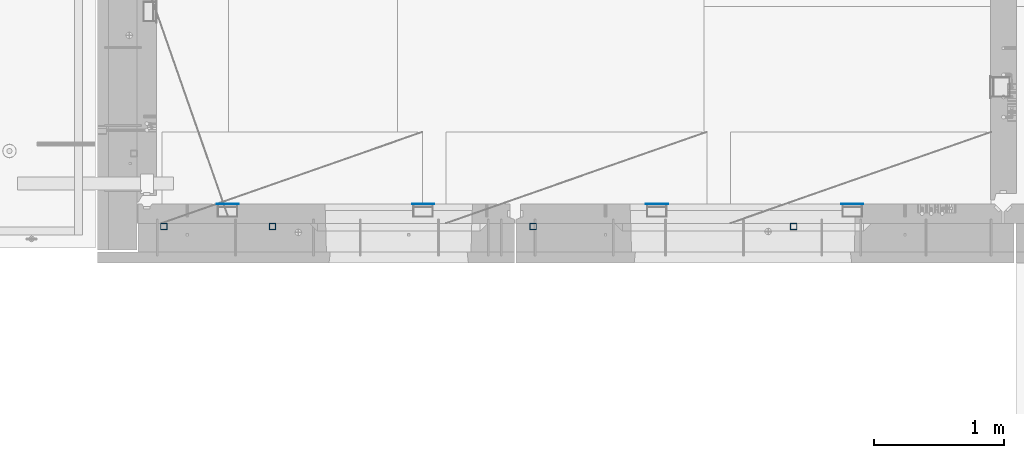
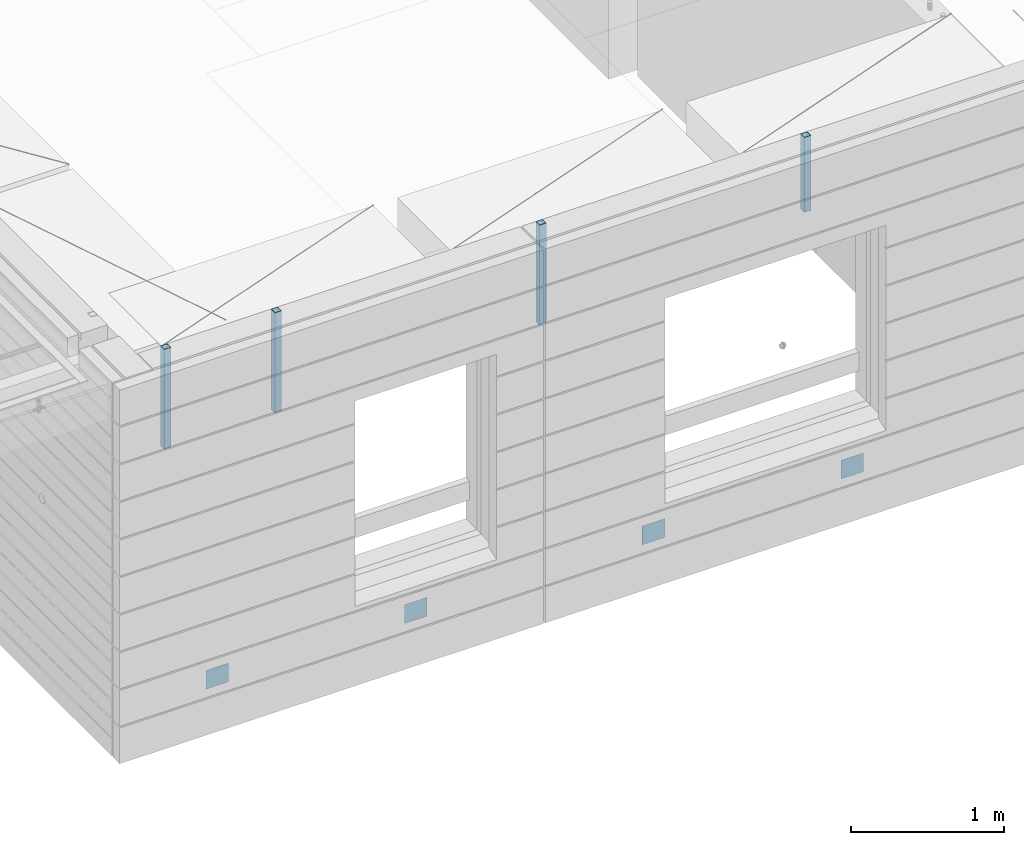
# One storey, part 8 of 334: 8 columns, 10 elements without a shape of their own.
"""IFC2X3 building model written with IfcOpenShell, lengths in millimetres."""

from ifc_helpers import new_model, si_unit, frame, origin_with_axes, place, context, subcontext, project, spatial, faceted_brep, material, type_object, element, aggregate, save


model = new_model("IFC2X3")

# Units and contexts
model_context = context("Model", 3, precision=1e-05, world=origin_with_axes())
body_context = subcontext(model_context, "Body", "Model", "MODEL_VIEW")
ifc_project = project(units=[si_unit("LENGTHUNIT", "METRE", prefix="MILLI"), si_unit("AREAUNIT", "SQUARE_METRE"), si_unit("VOLUMEUNIT", "CUBIC_METRE"), si_unit("MASSUNIT", "GRAM", prefix="KILO"), si_unit("TIMEUNIT", "SECOND"), si_unit("PLANEANGLEUNIT", "RADIAN"), si_unit("SOLIDANGLEUNIT", "STERADIAN"), si_unit("THERMODYNAMICTEMPERATUREUNIT", "DEGREE_CELSIUS"), si_unit("LUMINOUSINTENSITYUNIT", "LUMEN")], contexts=[model_context])

# Site, building, storey
site_placement = place(None, origin_with_axes())
site = spatial("IfcSite", under=ifc_project, at=site_placement, CompositionType="ELEMENT")
building_placement = place(site_placement, origin_with_axes())
building = spatial("IfcBuilding", under=site, at=building_placement, CompositionType="ELEMENT")
storey_placement = place(building_placement, origin_with_axes())
storey = spatial("IfcBuildingStorey", under=building, at=storey_placement, Name="3", CompositionType="ELEMENT", Elevation=0.0)

# Assemblies, columns
assembly_1_placement = place(storey_placement, origin_with_axes())
assembly_1 = element("IfcElementAssembly", 1, at=assembly_1_placement, inside=storey, AssemblyPlace="NOTDEFINED", PredefinedType="REINFORCEMENT_UNIT")
assembly_2_placement = place(assembly_1_placement, origin_with_axes())
assembly_2 = element("IfcElementAssembly", 2, at=assembly_2_placement, Name="Steel Assembly", AssemblyPlace="NOTDEFINED", PredefinedType="NOTDEFINED")
ifc_material_1 = material(Name="Undefined")
column_type_1 = type_object("IfcColumnType", PredefinedType="NOTDEFINED")
column_1_placement = place(assembly_2_placement, frame((10705.0, 7999.00000000618, 87755.0), z_axis=(0.0, 1.0, 0.0), x_axis=(0.0, 0.0, 1.0)))
column_1 = element("IfcColumn", 3, at=column_1_placement, type_object=column_type_1, material=ifc_material_1, Name="SPK2", context=body_context, shape_type="Brep", body=[
    faceted_brep([(0.0, 85.0, -1.0), (0.0, 85.0, 1.0), (150.0, 85.0, 1.0), (150.0, 85.0, -1.0), (0.0, -85.0, 1.0), (150.0, -85.0, 1.0), (0.0, -85.0, -1.0), (150.0, -85.0, -1.0)], [[[0, 1, 2, 3]], [[1, 4, 5, 2]], [[4, 6, 7, 5]], [[6, 0, 3, 7]], [[5, 7, 3, 2]], [[6, 4, 1, 0]]]),
])
aggregate(assembly_2, [column_1])
assembly_3_placement = place(assembly_1_placement, origin_with_axes())
assembly_3 = element("IfcElementAssembly", 4, at=assembly_3_placement, Name="Steel Assembly", AssemblyPlace="NOTDEFINED", PredefinedType="NOTDEFINED")
column_2_placement = place(assembly_3_placement, frame((12205.0, 7999.00000000618, 87755.0), z_axis=(0.0, 1.0, 0.0), x_axis=(0.0, 0.0, 1.0)))
column_2 = element("IfcColumn", 5, at=column_2_placement, type_object=column_type_1, material=ifc_material_1, Name="SPK2", context=body_context, shape_type="Brep", body=[
    faceted_brep([(0.0, 85.0, -1.0), (0.0, 85.0, 1.0), (150.0, 85.0, 1.0), (150.0, 85.0, -1.0), (0.0, -85.0, 1.0), (150.0, -85.0, 1.0), (0.0, -85.0, -1.0), (150.0, -85.0, -1.0)], [[[0, 1, 2, 3]], [[1, 4, 5, 2]], [[4, 6, 7, 5]], [[6, 0, 3, 7]], [[5, 7, 3, 2]], [[6, 4, 1, 0]]]),
])
aggregate(assembly_3, [column_2])

assembly_4_placement = place(storey_placement, origin_with_axes())
assembly_4 = element("IfcElementAssembly", 6, at=assembly_4_placement, inside=storey, AssemblyPlace="NOTDEFINED", PredefinedType="REINFORCEMENT_UNIT")
assembly_5_placement = place(assembly_4_placement, origin_with_axes())
assembly_5 = element("IfcElementAssembly", 7, at=assembly_5_placement, Name="Steel Assembly", AssemblyPlace="NOTDEFINED", PredefinedType="NOTDEFINED")
column_3_placement = place(assembly_5_placement, frame((14000.0, 7999.00000000618, 87755.0), z_axis=(0.0, 1.0, 0.0), x_axis=(0.0, 0.0, 1.0)))
column_3 = element("IfcColumn", 8, at=column_3_placement, type_object=column_type_1, material=ifc_material_1, Name="SPK2", context=body_context, shape_type="Brep", body=[
    faceted_brep([(0.0, 85.0, -1.0), (0.0, 85.0, 1.0), (150.0, 85.0, 1.0), (150.0, 85.0, -1.0), (0.0, -85.0, 1.0), (150.0, -85.0, 1.0), (0.0, -85.0, -1.0), (150.0, -85.0, -1.0)], [[[0, 1, 2, 3]], [[1, 4, 5, 2]], [[4, 6, 7, 5]], [[6, 0, 3, 7]], [[5, 7, 3, 2]], [[6, 4, 1, 0]]]),
])
aggregate(assembly_5, [column_3])
assembly_6_placement = place(assembly_4_placement, origin_with_axes())
assembly_6 = element("IfcElementAssembly", 9, at=assembly_6_placement, Name="Steel Assembly", AssemblyPlace="NOTDEFINED", PredefinedType="NOTDEFINED")
column_4_placement = place(assembly_6_placement, frame((15500.0, 7998.99999999844, 87754.9999999985), z_axis=(0.0, 1.0, 0.0), x_axis=(0.0, 0.0, 1.0)))
column_4 = element("IfcColumn", 10, at=column_4_placement, type_object=column_type_1, material=ifc_material_1, Name="SPK2", context=body_context, shape_type="Brep", body=[
    faceted_brep([(0.0, 85.0, -1.0), (0.0, 85.0, 1.0), (150.0, 85.0, 1.0), (150.0, 85.0, -1.0), (0.0, -85.0, 1.0), (150.0, -85.0, 1.0), (0.0, -85.0, -1.0), (150.0, -85.0, -1.0)], [[[0, 1, 2, 3]], [[1, 4, 5, 2]], [[4, 6, 7, 5]], [[6, 0, 3, 7]], [[5, 7, 3, 2]], [[6, 4, 1, 0]]]),
])
aggregate(assembly_6, [column_4])

# Assembly, column
assembly_7_placement = place(assembly_1_placement, origin_with_axes())
assembly_7 = element("IfcElementAssembly", 11, at=assembly_7_placement, Name="Steel Assembly", AssemblyPlace="NOTDEFINED", PredefinedType="RIGID_FRAME")
ifc_material_2 = material(Name="STEEL/S355J2")
column_type_2 = type_object("IfcColumnType", Name="50X50X3", PredefinedType="NOTDEFINED")
column_5_placement = place(assembly_7_placement, frame((11050.0, 7825.0, 89940.0), z_axis=(-1.0, 3.00000001838171e-08, 0.0), x_axis=(0.0, 0.0, 1.0)))
column_5 = element("IfcColumn", 12, at=column_5_placement, type_object=column_type_2, material=ifc_material_2, ObjectType="50X50X3", context=body_context, shape_type="Brep", body=[
    faceted_brep([(0.0, 22.0, -22.0), (0.0, -22.0, -22.0), (800.0, -22.0, -22.0), (800.0, 22.0, -22.0), (0.0, -22.0, 22.0), (800.0, -22.0, 22.0), (0.0, 22.0, 22.0), (800.0, 22.0, 22.0), (0.0, 25.0, -25.0), (0.0, 25.0, 25.0), (800.0, 25.0, 25.0), (800.0, 25.0, -25.0), (0.0, -25.0, 25.0), (800.0, -25.0, 25.0), (0.0, -25.0, -25.0), (800.0, -25.0, -25.0)], [[[0, 1, 2, 3]], [[1, 4, 5, 2]], [[4, 6, 7, 5]], [[6, 0, 3, 7]], [[8, 9, 10, 11]], [[9, 12, 13, 10]], [[12, 14, 15, 13]], [[14, 8, 11, 15]], [[13, 15, 11, 10], [5, 7, 3, 2]], [[14, 12, 9, 8], [6, 4, 1, 0]]]),
])
aggregate(assembly_7, [column_5])

assembly_8_placement = place(assembly_4_placement, origin_with_axes())
assembly_8 = element("IfcElementAssembly", 13, at=assembly_8_placement, Name="Steel Assembly", AssemblyPlace="NOTDEFINED", PredefinedType="RIGID_FRAME")
column_6_placement = place(assembly_8_placement, frame((15050.0, 7825.0, 90140.0), z_axis=(-1.0, 3.00000001838171e-08, 0.0), x_axis=(0.0, 0.0, 1.0)))
column_6 = element("IfcColumn", 14, at=column_6_placement, type_object=column_type_2, material=ifc_material_2, ObjectType="50X50X3", context=body_context, shape_type="Brep", body=[
    faceted_brep([(0.0, 22.0, -22.0), (0.0, -22.0, -22.0), (600.0, -22.0, -22.0), (600.0, 22.0, -22.0), (0.0, -22.0, 22.0), (600.0, -22.0, 22.0), (0.0, 22.0, 22.0), (600.0, 22.0, 22.0), (0.0, 25.0, -25.0), (0.0, 25.0, 25.0), (600.0, 25.0, 25.0), (600.0, 25.0, -25.0), (0.0, -25.0, 25.0), (600.0, -25.0, 25.0), (0.0, -25.0, -25.0), (600.0, -25.0, -25.0)], [[[0, 1, 2, 3]], [[1, 4, 5, 2]], [[4, 6, 7, 5]], [[6, 0, 3, 7]], [[8, 9, 10, 11]], [[9, 12, 13, 10]], [[12, 14, 15, 13]], [[14, 8, 11, 15]], [[13, 15, 11, 10], [5, 7, 3, 2]], [[14, 12, 9, 8], [6, 4, 1, 0]]]),
])
aggregate(assembly_8, [column_6])

# Assembly
assembly_9_placement = place(assembly_4_placement, origin_with_axes())
assembly_9 = element("IfcElementAssembly", 15, at=assembly_9_placement, Name="Steel Assembly", AssemblyPlace="NOTDEFINED", PredefinedType="RIGID_FRAME")

aggregate(assembly_4, [assembly_5, assembly_6, assembly_8, assembly_9])

# Column
column_7_placement = place(assembly_9_placement, frame((13050.0, 7825.0, 89940.0), z_axis=(-1.0, 3.00000001838171e-08, 0.0), x_axis=(0.0, 0.0, 1.0)))
column_7 = element("IfcColumn", 16, at=column_7_placement, type_object=column_type_2, material=ifc_material_2, ObjectType="50X50X3", context=body_context, shape_type="Brep", body=[
    faceted_brep([(0.0, 22.0, -22.0), (0.0, -22.0, -22.0), (800.0, -22.0, -22.0), (800.0, 22.0, -22.0), (0.0, -22.0, 22.0), (800.0, -22.0, 22.0), (0.0, 22.0, 22.0), (800.0, 22.0, 22.0), (0.0, 25.0, -25.0), (0.0, 25.0, 25.0), (800.0, 25.0, 25.0), (800.0, 25.0, -25.0), (0.0, -25.0, 25.0), (800.0, -25.0, 25.0), (0.0, -25.0, -25.0), (800.0, -25.0, -25.0)], [[[0, 1, 2, 3]], [[1, 4, 5, 2]], [[4, 6, 7, 5]], [[6, 0, 3, 7]], [[8, 9, 10, 11]], [[9, 12, 13, 10]], [[12, 14, 15, 13]], [[14, 8, 11, 15]], [[13, 15, 11, 10], [5, 7, 3, 2]], [[14, 12, 9, 8], [6, 4, 1, 0]]]),
])

aggregate(assembly_9, [column_7])

# Assembly
assembly_10_placement = place(assembly_1_placement, origin_with_axes())
assembly_10 = element("IfcElementAssembly", 17, at=assembly_10_placement, Name="Steel Assembly", AssemblyPlace="NOTDEFINED", PredefinedType="RIGID_FRAME")

aggregate(assembly_1, [assembly_7, assembly_2, assembly_3, assembly_10])

# Column
column_8_placement = place(assembly_10_placement, frame((10215.0, 7825.0, 89940.0), z_axis=(-1.0, 3.00000001838171e-08, 0.0), x_axis=(0.0, 0.0, 1.0)))
column_8 = element("IfcColumn", 18, at=column_8_placement, type_object=column_type_2, material=ifc_material_2, ObjectType="50X50X3", context=body_context, shape_type="Brep", body=[
    faceted_brep([(0.0, 22.0, -22.0), (0.0, -22.0, -22.0), (800.0, -22.0, -22.0), (800.0, 22.0, -22.0), (0.0, -22.0, 22.0), (800.0, -22.0, 22.0), (0.0, 22.0, 22.0), (800.0, 22.0, 22.0), (0.0, 25.0, -25.0), (0.0, 25.0, 25.0), (800.0, 25.0, 25.0), (800.0, 25.0, -25.0), (0.0, -25.0, 25.0), (800.0, -25.0, 25.0), (0.0, -25.0, -25.0), (800.0, -25.0, -25.0)], [[[0, 1, 2, 3]], [[1, 4, 5, 2]], [[4, 6, 7, 5]], [[6, 0, 3, 7]], [[8, 9, 10, 11]], [[9, 12, 13, 10]], [[12, 14, 15, 13]], [[14, 8, 11, 15]], [[13, 15, 11, 10], [5, 7, 3, 2]], [[14, 12, 9, 8], [6, 4, 1, 0]]]),
])

aggregate(assembly_10, [column_8])

save(model, "model.ifc")
